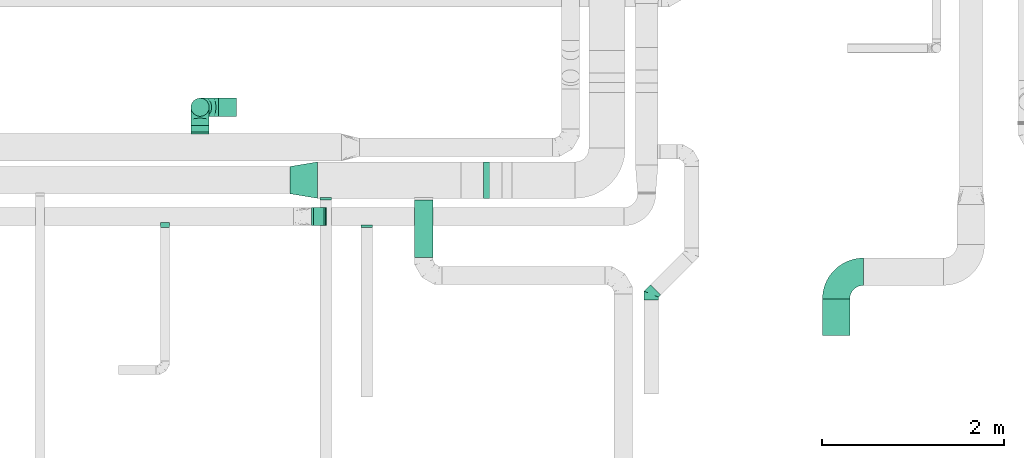
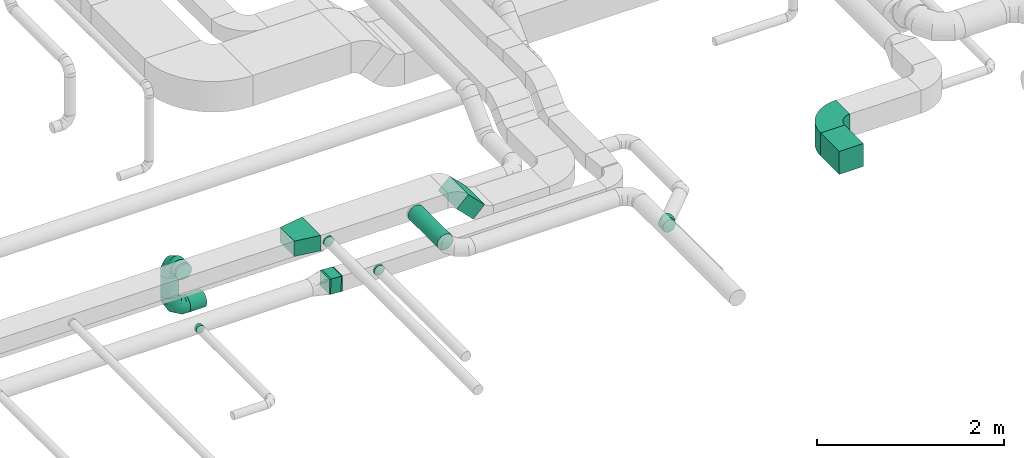
# One storey, part 26 of 60: 11 flow fittings, 7 flow segments.
"""IFC2X3 building model written with IfcOpenShell, lengths in millimetres."""

from ifc_helpers import new_model, entity, si_unit, converted_unit, derived_unit, direction, frame, frame_2d, origin, origin_2d_with_axis, place, context, subcontext, project, spatial, polyline, circle_curve, parameter, trimmed, segment, composite_curve, rectangle, circle, outline, extrude, faceted_brep, source, transform, mapped, material, type_object, type_shapes, element, save


model = new_model("IFC2X3")

# Units and contexts
model_context = context("Model", 3, precision=0.01, world=origin(), true_north=direction((6.12303176911189e-17, 1.0)))
body_context = subcontext(model_context, "Body", "Model", "MODEL_VIEW")
ifc_project = project(units=[si_unit("LENGTHUNIT", "METRE", prefix="MILLI"), si_unit("AREAUNIT", "SQUARE_METRE"), si_unit("VOLUMEUNIT", "CUBIC_METRE"), converted_unit("PLANEANGLEUNIT", "DEGREE", entity("IfcRatioMeasure", 0.0174532925199433), si_unit("PLANEANGLEUNIT", "RADIAN"), dimensions=[0, 0, 0, 0, 0, 0, 0]), si_unit("MASSUNIT", "GRAM", prefix="KILO"), derived_unit("MASSDENSITYUNIT", [(si_unit("MASSUNIT", "GRAM", prefix="KILO"), 1), (si_unit("LENGTHUNIT", "METRE"), -3)]), derived_unit("MOMENTOFINERTIAUNIT", [(si_unit("LENGTHUNIT", "METRE"), 4)]), si_unit("TIMEUNIT", "SECOND"), si_unit("FREQUENCYUNIT", "HERTZ"), si_unit("THERMODYNAMICTEMPERATUREUNIT", "DEGREE_CELSIUS"), derived_unit("THERMALTRANSMITTANCEUNIT", [(si_unit("MASSUNIT", "GRAM", prefix="KILO"), 1), (si_unit("THERMODYNAMICTEMPERATUREUNIT", "KELVIN"), -1), (si_unit("TIMEUNIT", "SECOND"), -3)]), derived_unit("VOLUMETRICFLOWRATEUNIT", [(si_unit("LENGTHUNIT", "METRE"), 3), (si_unit("TIMEUNIT", "SECOND"), -1)]), derived_unit("MASSFLOWRATEUNIT", [(si_unit("MASSUNIT", "GRAM", prefix="KILO"), 1), (si_unit("TIMEUNIT", "SECOND"), -1)]), derived_unit("ROTATIONALFREQUENCYUNIT", [(si_unit("TIMEUNIT", "SECOND"), -1)]), si_unit("ELECTRICCURRENTUNIT", "AMPERE"), si_unit("ELECTRICVOLTAGEUNIT", "VOLT"), si_unit("POWERUNIT", "WATT"), si_unit("FORCEUNIT", "NEWTON", prefix="KILO"), si_unit("ILLUMINANCEUNIT", "LUX"), si_unit("LUMINOUSFLUXUNIT", "LUMEN"), si_unit("LUMINOUSINTENSITYUNIT", "CANDELA"), derived_unit("USERDEFINED", [(si_unit("MASSUNIT", "GRAM", prefix="KILO"), -1), (si_unit("LENGTHUNIT", "METRE"), -2), (si_unit("TIMEUNIT", "SECOND"), 3), (si_unit("LUMINOUSFLUXUNIT", "LUMEN"), 1)]), derived_unit("LINEARVELOCITYUNIT", [(si_unit("LENGTHUNIT", "METRE"), 1), (si_unit("TIMEUNIT", "SECOND"), -1)]), si_unit("PRESSUREUNIT", "PASCAL"), derived_unit("USERDEFINED", [(si_unit("LENGTHUNIT", "METRE"), -2), (si_unit("MASSUNIT", "GRAM", prefix="KILO"), 1), (si_unit("TIMEUNIT", "SECOND"), -2)]), derived_unit("LINEARFORCEUNIT", [(si_unit("MASSUNIT", "GRAM", prefix="KILO"), 1), (si_unit("LENGTHUNIT", "METRE"), 1), (si_unit("TIMEUNIT", "SECOND"), -2), (si_unit("LENGTHUNIT", "METRE"), -1)]), derived_unit("PLANARFORCEUNIT", [(si_unit("MASSUNIT", "GRAM", prefix="KILO"), 1), (si_unit("LENGTHUNIT", "METRE"), 1), (si_unit("TIMEUNIT", "SECOND"), -2), (si_unit("LENGTHUNIT", "METRE"), -2)])], contexts=[model_context])

# Site, building, storey
site_placement = place(None, origin())
site = spatial("IfcSite", under=ifc_project, at=site_placement, CompositionType="ELEMENT")
building_placement = place(site_placement, origin())
building = spatial("IfcBuilding", under=site, at=building_placement, CompositionType="ELEMENT")
storey_placement = place(building_placement, frame((0.0, 0.0, 19800.0)))
storey = spatial("IfcBuildingStorey", under=building, at=storey_placement, CompositionType="ELEMENT", Elevation=19800.0)

# Flow segments
duct_segment_type_1 = type_object("IfcDuctSegmentType", PredefinedType="NOTDEFINED")
flow_segment_1_placement = place(storey_placement, frame((45074.61, 5025.34, 3252.51)))
element("IfcFlowSegment", 1, at=flow_segment_1_placement, inside=storey, type_object=duct_segment_type_1, context=body_context, shape_type="SweptSolid", body=[
    extrude(rectangle(XDim=287.867965644102, YDim=199.999999999998, at=origin_2d_with_axis()), frame((172.49, 0.0, 172.49), z_axis=(0.0, 1.0, 0.0), x_axis=(0.707106781186517, 0.0, -0.707106781186578)), (0.0, 0.0, 1.0), 400.000000000001),
])
flow_segment_2_placement = place(storey_placement, frame((48935.38, 3519.45, 3470.0)))
element("IfcFlowSegment", 2, at=flow_segment_2_placement, inside=storey, type_object=duct_segment_type_1, context=body_context, shape_type="SweptSolid", body=[
    extrude(rectangle(XDim=400.000000000009, YDim=300.000000000001, at=origin_2d_with_axis()), frame((150.0, 200.0, 0.0), z_axis=(0.0, 0.0, 1.0), x_axis=(0.0, -1.0, 0.0)), (0.0, 0.0, 1.0), 300.000000000001),
])
flow_segment_3_placement = place(storey_placement, frame((43335.44, 4724.52, 3120.7)))
element("IfcFlowSegment", 3, at=flow_segment_3_placement, inside=storey, type_object=duct_segment_type_1, context=body_context, shape_type="SweptSolid", body=[
    extrude(rectangle(XDim=129.930530110866, YDim=200.0, at=origin_2d_with_axis()), frame((64.81, 100.0, 4.42), z_axis=(0.0680418664621352, 0.0, 0.997682466723932), x_axis=(0.997682466723932, 0.0, -0.0680418664621352)), (0.0, 0.0, 1.0), 200.000000000001),
])
duct_segment_type_2 = type_object("IfcDuctSegmentType", PredefinedType="NOTDEFINED")
flow_segment_4_placement = place(storey_placement, frame((42000.81, 5755.05, 3148.4)))
element("IfcFlowSegment", 4, at=flow_segment_4_placement, inside=storey, type_object=duct_segment_type_2, context=body_context, shape_type="SweptSolid", body=[
    extrude(circle(Radius=100.0, at=origin_2d_with_axis()), frame((101.6, 0.0, 101.6), z_axis=(0.0, 1.0, 0.0), x_axis=(1.0, 0.0, 0.0)), (0.0, 0.0, 1.0), 69.9999999999678),
])
flow_segment_5_placement = place(storey_placement, frame((42000.81, 5923.46, 2787.5)))
element("IfcFlowSegment", 5, at=flow_segment_5_placement, inside=storey, type_object=duct_segment_type_2, context=body_context, shape_type="SweptSolid", body=[
    extrude(circle(Radius=100.0, at=origin_2d_with_axis()), frame((101.6, 101.6, 0.0), z_axis=(0.0, 0.0, 1.0), x_axis=(-1.0, 0.0, 0.0)), (0.0, 0.0, 1.0), 262.500000000001),
])
flow_segment_6_placement = place(storey_placement, frame((42302.4, 5923.46, 2485.9)))
element("IfcFlowSegment", 6, at=flow_segment_6_placement, inside=storey, type_object=duct_segment_type_2, context=body_context, shape_type="SweptSolid", body=[
    extrude(circle(Radius=100.0, at=origin_2d_with_axis()), frame((0.0, 101.6, 101.6), z_axis=(1.0, 0.0, 0.0), x_axis=(0.0, -1.0, 0.0)), (0.0, 0.0, 1.0), 200.000000000015),
])
flow_segment_7_placement = place(storey_placement, frame((44456.24, 4376.59, 3498.4)))
element("IfcFlowSegment", 7, at=flow_segment_7_placement, inside=storey, type_object=duct_segment_type_2, context=body_context, shape_type="SweptSolid", body=[
    extrude(circle(Radius=100.0, at=origin_2d_with_axis()), frame((101.6, 0.0, 101.6), z_axis=(0.0, 1.0, 0.0), x_axis=(-1.0, 0.0, 0.0)), (0.0, 0.0, 1.0), 628.750000000001),
])

# Flow fittings
ifc_material = material()
duct_fitting_type_1 = type_object("IfcDuctFittingType", PredefinedType="NOTDEFINED", material=ifc_material)
shared_shape_1 = source(origin(), body_context, "Body", "SweptSolid", [
    extrude(outline(polyline([(-180.84, -172.62), (123.3, -172.62), (172.62, 123.3), (-115.08, 221.94), (-180.84, -172.62)])), frame((150.0, 0.0, -100.0), z_axis=(0.0, 0.0, 1.0), x_axis=(0.986393923832144, 0.164398987305356, 0.0)), (0.0, 0.0, 1.0), 200.0),
])
type_shapes(duct_fitting_type_1, [shared_shape_1])
flow_fitting_1_placement = place(storey_placement, frame((43391.97, 5225.34, 3600.0), z_axis=(0.0, 0.0, 1.0), x_axis=(-1.0, 0.0, 0.0)))
element("IfcFlowFitting", 8, at=flow_fitting_1_placement, inside=storey, type_object=duct_fitting_type_1, material=ifc_material, context=body_context, shape_type="MappedRepresentation", body=[
    mapped(shared_shape_1, transform((0.0, 0.0, 0.0), scale=1.0)),
])
duct_fitting_type_2 = type_object("IfcDuctFittingType", PredefinedType="NOTDEFINED", material=ifc_material)
shared_shape_2 = source(origin(), body_context, "Body", "Brep", [
    faceted_brep([(-200.0, 0.0, -100.0), (-200.0, -25.88, -96.59), (-200.0, -50.0, -86.6), (-200.0, -70.71, -70.71), (-200.0, -86.6, -50.0), (-200.0, -96.59, -25.88), (-200.0, -100.0, 0.0), (-200.0, -96.59, 25.88), (-200.0, -86.6, 50.0), (-200.0, -70.71, 70.71), (-200.0, -50.0, 86.6), (-200.0, -25.88, 96.59), (-200.0, 0.0, 100.0), (-200.0, 25.88, 96.59), (-200.0, 50.0, 86.6), (-200.0, 70.71, 70.71), (-200.0, 86.6, 50.0), (-200.0, 96.59, 25.88), (-200.0, 100.0, 0.0), (-200.0, 96.59, -25.88), (-200.0, 86.6, -50.0), (-200.0, 70.71, -70.71), (-200.0, 50.0, -86.6), (-200.0, 25.88, -96.59), (-153.35, 25.88, 96.59), (-159.81, 50.0, 86.6), (-146.41, 0.0, 100.0), (-165.36, 70.71, 70.71), (-172.29, 96.59, 25.88), (-173.21, 100.0, 0.0), (-169.62, 86.6, 50.0), (-169.62, 86.6, -50.0), (-165.36, 70.71, -70.71), (-172.29, 96.59, -25.88), (-153.35, 25.88, -96.59), (-146.41, 0.0, -100.0), (-159.81, 50.0, -86.6), (-139.48, -25.88, -96.59), (-133.01, -50.0, -86.6), (-127.46, -70.71, -70.71), (-123.21, -86.6, -50.0), (-120.53, -96.59, -25.88), (-119.62, -100.0, 0.0), (-120.53, -96.59, 25.88), (-123.21, -86.6, 50.0), (-127.46, -70.71, 70.71), (-133.01, -50.0, 86.6), (-139.48, -25.88, 96.59), (-72.54, 72.54, 96.59), (-90.19, 90.19, 86.6), (-53.59, 53.59, 100.0), (-105.35, 105.35, 70.71), (-116.99, 116.99, 50.0), (-124.3, 124.3, 25.88), (-126.79, 126.79, 0.0), (-124.3, 124.3, -25.88), (-116.99, 116.99, -50.0), (-105.35, 105.35, -70.71), (-72.54, 72.54, -96.59), (-53.59, 53.59, -100.0), (-90.19, 90.19, -86.6), (-34.64, 34.64, -96.59), (-16.99, 16.99, -86.6), (-1.83, 1.83, -70.71), (9.81, -9.81, -50.0), (17.12, -17.12, -25.88), (19.62, -19.62, 0.0), (17.12, -17.12, 25.88), (9.81, -9.81, 50.0), (-1.83, 1.83, 70.71), (-16.99, 16.99, 86.6), (-34.64, 34.64, 96.59), (-25.88, 153.35, 96.59), (-50.0, 159.81, 86.6), (0.0, 146.41, 100.0), (-70.71, 165.36, 70.71), (-86.6, 169.62, 50.0), (-96.59, 172.29, 25.88), (-100.0, 173.21, 0.0), (-96.59, 172.29, -25.88), (-86.6, 169.62, -50.0), (-70.71, 165.36, -70.71), (-25.88, 153.35, -96.59), (0.0, 146.41, -100.0), (-50.0, 159.81, -86.6), (25.88, 139.48, -96.59), (50.0, 133.01, -86.6), (70.71, 127.46, -70.71), (86.6, 123.21, -50.0), (96.59, 120.53, -25.88), (100.0, 119.62, 0.0), (96.59, 120.53, 25.88), (86.6, 123.21, 50.0), (70.71, 127.46, 70.71), (50.0, 133.01, 86.6), (25.88, 139.48, 96.59), (-25.88, 200.0, -96.59), (-50.0, 200.0, -86.6), (-70.71, 200.0, -70.71), (-86.6, 200.0, -50.0), (-96.59, 200.0, -25.88), (-100.0, 200.0, 0.0), (-96.59, 200.0, 25.88), (-86.6, 200.0, 50.0), (-70.71, 200.0, 70.71), (-50.0, 200.0, 86.6), (-25.88, 200.0, 96.59), (0.0, 200.0, 100.0), (25.88, 200.0, 96.59), (50.0, 200.0, 86.6), (70.71, 200.0, 70.71), (86.6, 200.0, 50.0), (96.59, 200.0, 25.88), (100.0, 200.0, 0.0), (96.59, 200.0, -25.88), (86.6, 200.0, -50.0), (70.71, 200.0, -70.71), (50.0, 200.0, -86.6), (25.88, 200.0, -96.59), (0.0, 200.0, -100.0)], [[[0, 1, 2, 3, 4, 5, 6, 7, 8, 9, 10, 11, 12, 13, 14, 15, 16, 17, 18, 19, 20, 21, 22, 23]], [[24, 25, 14, 13]], [[26, 24, 13, 12]], [[14, 25, 27, 15]], [[28, 29, 18, 17]], [[30, 28, 17, 16]], [[15, 27, 30, 16]], [[20, 31, 32, 21]], [[33, 31, 20, 19]], [[18, 29, 33, 19]], [[34, 35, 0, 23]], [[36, 34, 23, 22]], [[32, 36, 22, 21]], [[1, 0, 35, 37]], [[2, 1, 37, 38]], [[38, 39, 3, 2]], [[5, 4, 40, 41]], [[6, 5, 41, 42]], [[39, 40, 4, 3]], [[6, 42, 43, 7]], [[7, 43, 44, 8]], [[8, 44, 45, 9]], [[9, 45, 46, 10]], [[10, 46, 47, 11]], [[26, 12, 11, 47]], [[48, 49, 25, 24]], [[50, 48, 24, 26]], [[27, 25, 49, 51]], [[52, 53, 28, 30]], [[51, 52, 30, 27]], [[29, 28, 53, 54]], [[55, 56, 31, 33]], [[54, 55, 33, 29]], [[32, 31, 56, 57]], [[58, 59, 35, 34]], [[60, 58, 34, 36]], [[57, 60, 36, 32]], [[37, 35, 59, 61]], [[38, 37, 61, 62]], [[39, 38, 62, 63]], [[41, 40, 64, 65]], [[42, 41, 65, 66]], [[63, 64, 40, 39]], [[43, 42, 66, 67]], [[44, 43, 67, 68]], [[68, 69, 45, 44]], [[46, 45, 69, 70]], [[47, 46, 70, 71]], [[26, 47, 71, 50]], [[72, 73, 49, 48]], [[74, 72, 48, 50]], [[51, 49, 73, 75]], [[76, 77, 53, 52]], [[75, 76, 52, 51]], [[54, 53, 77, 78]], [[79, 80, 56, 55]], [[78, 79, 55, 54]], [[57, 56, 80, 81]], [[82, 83, 59, 58]], [[84, 82, 58, 60]], [[81, 84, 60, 57]], [[61, 59, 83, 85]], [[62, 61, 85, 86]], [[63, 62, 86, 87]], [[65, 64, 88, 89]], [[66, 65, 89, 90]], [[87, 88, 64, 63]], [[67, 66, 90, 91]], [[68, 67, 91, 92]], [[92, 93, 69, 68]], [[70, 69, 93, 94]], [[71, 70, 94, 95]], [[50, 71, 95, 74]], [[96, 97, 98, 99, 100, 101, 102, 103, 104, 105, 106, 107, 108, 109, 110, 111, 112, 113, 114, 115, 116, 117, 118, 119]], [[72, 74, 107, 106]], [[73, 72, 106, 105]], [[75, 73, 105, 104]], [[102, 101, 78, 77]], [[103, 102, 77, 76]], [[75, 104, 103, 76]], [[78, 101, 100, 79]], [[79, 100, 99, 80]], [[80, 99, 98, 81]], [[84, 97, 96, 82]], [[82, 96, 119, 83]], [[84, 81, 98, 97]], [[118, 117, 86, 85]], [[119, 118, 85, 83]], [[116, 87, 86, 117]], [[88, 115, 114, 89]], [[89, 114, 113, 90]], [[115, 88, 87, 116]], [[91, 90, 113, 112]], [[92, 91, 112, 111]], [[111, 110, 93, 92]], [[95, 94, 109, 108]], [[74, 95, 108, 107]], [[110, 109, 94, 93]]]),
])
type_shapes(duct_fitting_type_2, [shared_shape_2])
for number, where, z_axis, x_axis in (
    (9, (42102.4, 6025.05, 3250.0), (-1.0, 0.0, 0.0), (0.0, 1.0, 0.0)),
    (10, (42102.4, 6025.05, 2587.5), (0.0, -1.0, 0.0), (0.0, 0.0, -1.0)),
):
    element("IfcFlowFitting", number, at=place(storey_placement, frame(where, z_axis=z_axis, x_axis=x_axis)), inside=storey, type_object=duct_fitting_type_2, material=ifc_material, context=body_context, shape_type="MappedRepresentation", body=[
        mapped(shared_shape_2, transform((0.0, 0.0, 0.0), scale=1.0)),
    ])
duct_fitting_type_3 = type_object("IfcDuctFittingType", PredefinedType="NOTDEFINED", material=ifc_material)
shared_shape_3 = source(origin(), body_context, "Body", "Brep", [
    faceted_brep([(20.0, 0.0, -62.5), (20.0, 16.18, -60.37), (20.0, 31.25, -54.13), (20.0, 44.19, -44.19), (20.0, 54.13, -31.25), (20.0, 60.37, -16.18), (20.0, 62.5, 0.0), (20.0, 60.37, 16.18), (20.0, 54.13, 31.25), (20.0, 44.19, 44.19), (20.0, 31.25, 54.13), (20.0, 16.18, 60.37), (20.0, 0.0, 62.5), (20.0, -16.18, 60.37), (20.0, -31.25, 54.13), (20.0, -44.19, 44.19), (20.0, -54.13, 31.25), (20.0, -60.37, 16.18), (20.0, -62.5, 0.0), (20.0, -60.37, -16.18), (20.0, -54.13, -31.25), (20.0, -44.19, -44.19), (20.0, -31.25, -54.13), (20.0, -16.18, -60.37), (0.0, 0.0, 62.5), (-6.1, 0.0, 62.5), (-6.1, -16.18, 60.37), (0.0, -16.18, 60.37), (-6.1, -31.25, 54.13), (0.0, -31.25, 54.13), (0.0, -44.19, 44.19), (-6.1, -44.19, 44.19), (0.0, -54.13, 31.25), (-6.1, -54.13, 31.25), (-6.1, -60.37, 16.18), (0.0, -60.37, 16.18), (-6.1, -62.5, 0.0), (0.0, -62.5, 0.0), (-6.1, -60.37, -16.18), (0.0, -60.37, -16.18), (-6.1, -54.13, -31.25), (0.0, -54.13, -31.25), (0.0, -44.19, -44.19), (-6.1, -44.19, -44.19), (0.0, -31.25, -54.13), (-6.1, -31.25, -54.13), (-6.1, -16.18, -60.37), (0.0, -16.18, -60.37), (-6.1, 0.0, -62.5), (0.0, 0.0, -62.5), (-6.1, 16.18, -60.37), (0.0, 16.18, -60.37), (-6.1, 31.25, -54.13), (0.0, 31.25, -54.13), (0.0, 44.19, -44.19), (-6.1, 44.19, -44.19), (0.0, 54.13, -31.25), (-6.1, 54.13, -31.25), (-6.1, 60.37, -16.18), (0.0, 60.37, -16.18), (-6.1, 62.5, 0.0), (0.0, 62.5, 0.0), (-6.1, 60.37, 16.18), (0.0, 60.37, 16.18), (-6.1, 54.13, 31.25), (0.0, 54.13, 31.25), (0.0, 44.19, 44.19), (-6.1, 44.19, 44.19), (0.0, 31.25, 54.13), (-6.1, 31.25, 54.13), (-6.1, 16.18, 60.37), (0.0, 16.18, 60.37)], [[[0, 1, 2, 3, 4, 5, 6, 7, 8, 9, 10, 11, 12, 13, 14, 15, 16, 17, 18, 19, 20, 21, 22, 23]], [[13, 12, 24, 25, 26, 27]], [[14, 13, 27, 26, 28, 29]], [[30, 15, 14, 29, 28, 31]], [[17, 16, 32, 33, 34, 35]], [[18, 17, 35, 34, 36, 37]], [[32, 16, 15, 30, 31, 33]], [[19, 18, 37, 36, 38, 39]], [[20, 19, 39, 38, 40, 41]], [[42, 21, 20, 41, 40, 43]], [[23, 22, 44, 45, 46, 47]], [[0, 23, 47, 46, 48, 49]], [[44, 22, 21, 42, 43, 45]], [[1, 0, 49, 48, 50, 51]], [[2, 1, 51, 50, 52, 53]], [[54, 3, 2, 53, 52, 55]], [[5, 4, 56, 57, 58, 59]], [[6, 5, 59, 58, 60, 61]], [[56, 4, 3, 54, 55, 57]], [[7, 6, 61, 60, 62, 63]], [[8, 7, 63, 62, 64, 65]], [[66, 9, 8, 65, 64, 67]], [[11, 10, 68, 69, 70, 71]], [[12, 11, 71, 70, 25, 24]], [[68, 10, 9, 66, 67, 69]], [[46, 45, 43, 40, 38, 36, 34, 33, 31, 28, 26, 25, 70, 69, 67, 64, 62, 60, 58, 57, 55, 52, 50, 48]]]),
])
type_shapes(duct_fitting_type_3, [shared_shape_3])
for number, where, z_axis, x_axis in (
    (11, (43480.63, 5025.34, 3600.0), (0.0, 0.0, -1.0), (0.0, -1.0, 0.0)),
    (12, (43931.49, 4724.52, 3250.0), (0.0, 0.0, -1.0), (0.0, -1.0, 0.0)),
):
    element("IfcFlowFitting", number, at=place(storey_placement, frame(where, z_axis=z_axis, x_axis=x_axis)), inside=storey, type_object=duct_fitting_type_3, material=ifc_material, context=body_context, shape_type="MappedRepresentation", body=[
        mapped(shared_shape_3, transform((0.0, 0.0, 0.0), scale=1.0)),
    ])
duct_fitting_type_4 = type_object("IfcDuctFittingType", PredefinedType="NOTDEFINED", material=ifc_material)
shared_shape_4 = source(origin(), body_context, "Body", "Brep", [
    faceted_brep([(-66.27, 0.0, -80.0), (-66.27, -20.71, -77.27), (-66.27, -40.0, -69.28), (-66.27, -56.57, -56.57), (-66.27, -69.28, -40.0), (-66.27, -77.27, -20.71), (-66.27, -80.0, 0.0), (-66.27, -77.27, 20.71), (-66.27, -69.28, 40.0), (-66.27, -56.57, 56.57), (-66.27, -40.0, 69.28), (-66.27, -20.71, 77.27), (-66.27, 0.0, 80.0), (-66.27, 20.71, 77.27), (-66.27, 40.0, 69.28), (-66.27, 56.57, 56.57), (-66.27, 69.28, 40.0), (-66.27, 77.27, 20.71), (-66.27, 80.0, 0.0), (-66.27, 77.27, -20.71), (-66.27, 69.28, -40.0), (-66.27, 56.57, -56.57), (-66.27, 40.0, -69.28), (-66.27, 20.71, -77.27), (-8.58, 20.71, 77.27), (-16.57, 40.0, 69.28), (0.0, 0.0, 80.0), (-23.43, 56.57, 56.57), (-28.7, 69.28, 40.0), (-32.01, 77.27, 20.71), (-33.14, 80.0, 0.0), (-32.01, 77.27, -20.71), (-28.7, 69.28, -40.0), (-23.43, 56.57, -56.57), (-8.58, 20.71, -77.27), (0.0, 0.0, -80.0), (-16.57, 40.0, -69.28), (8.58, -20.71, -77.27), (16.57, -40.0, -69.28), (23.43, -56.57, -56.57), (28.7, -69.28, -40.0), (32.01, -77.27, -20.71), (33.14, -80.0, 0.0), (32.01, -77.27, 20.71), (28.7, -69.28, 40.0), (23.43, -56.57, 56.57), (16.57, -40.0, 69.28), (8.58, -20.71, 77.27), (46.86, 46.86, 80.0), (32.22, 61.5, 77.27), (18.58, 75.15, 69.28), (6.86, 86.86, 56.57), (-2.13, 95.85, 40.0), (-7.78, 101.5, 20.71), (-9.71, 103.43, 0.0), (-7.78, 101.5, -20.71), (-2.13, 95.85, -40.0), (6.86, 86.86, -56.57), (18.58, 75.15, -69.28), (32.22, 61.5, -77.27), (46.86, 46.86, -80.0), (61.5, 32.22, -77.27), (75.15, 18.58, -69.28), (86.86, 6.86, -56.57), (95.85, -2.13, -40.0), (101.5, -7.78, -20.71), (103.43, -9.71, 0.0), (101.5, -7.78, 20.71), (95.85, -2.13, 40.0), (86.86, 6.86, 56.57), (75.15, 18.58, 69.28), (61.5, 32.22, 77.27)], [[[0, 1, 2, 3, 4, 5, 6, 7, 8, 9, 10, 11, 12, 13, 14, 15, 16, 17, 18, 19, 20, 21, 22, 23]], [[24, 25, 14, 13]], [[26, 24, 13, 12]], [[14, 25, 27, 15]], [[28, 29, 17, 16]], [[28, 16, 15, 27]], [[30, 18, 17, 29]], [[31, 32, 20, 19]], [[30, 31, 19, 18]], [[32, 33, 21, 20]], [[34, 35, 0, 23]], [[36, 34, 23, 22]], [[33, 36, 22, 21]], [[1, 0, 35, 37]], [[2, 1, 37, 38]], [[38, 39, 3, 2]], [[5, 4, 40, 41]], [[6, 5, 41, 42]], [[39, 40, 4, 3]], [[6, 42, 43, 7]], [[7, 43, 44, 8]], [[8, 44, 45, 9]], [[9, 45, 46, 10]], [[10, 46, 47, 11]], [[26, 12, 11, 47]], [[24, 26, 48, 49]], [[25, 24, 49, 50]], [[27, 25, 50, 51]], [[29, 28, 52, 53]], [[30, 29, 53, 54]], [[51, 52, 28, 27]], [[30, 54, 55, 31]], [[31, 55, 56, 32]], [[57, 33, 32, 56]], [[36, 58, 59, 34]], [[34, 59, 60, 35]], [[58, 36, 33, 57]], [[35, 60, 61, 37]], [[37, 61, 62, 38]], [[63, 39, 38, 62]], [[40, 64, 65, 41]], [[41, 65, 66, 42]], [[64, 40, 39, 63]], [[43, 42, 66, 67]], [[44, 43, 67, 68]], [[68, 69, 45, 44]], [[47, 46, 70, 71]], [[26, 47, 71, 48]], [[69, 70, 46, 45]], [[59, 58, 57, 56, 55, 54, 53, 52, 51, 50, 49, 48, 71, 70, 69, 68, 67, 66, 65, 64, 63, 62, 61, 60]]]),
])
type_shapes(duct_fitting_type_4, [shared_shape_4])
flow_fitting_2_placement = place(storey_placement, frame((47056.97, 3972.54, 3219.89), z_axis=(0.0, 0.0, 1.0), x_axis=(-0.707106781186556, -0.707106781186539, 0.0)))
element("IfcFlowFitting", 13, at=flow_fitting_2_placement, inside=storey, type_object=duct_fitting_type_4, material=ifc_material, context=body_context, shape_type="MappedRepresentation", body=[
    mapped(shared_shape_4, transform((0.0, 0.0, 0.0), scale=1.0)),
])
duct_fitting_type_5 = type_object("IfcDuctFittingType", PredefinedType="NOTDEFINED", material=ifc_material)
shared_shape_5 = source(origin(), body_context, "Body", "Brep", [
    faceted_brep([(20.0, 25.88, -96.59), (20.0, 50.0, -86.6), (20.0, 70.71, -70.71), (20.0, 86.6, -50.0), (20.0, 96.59, -25.88), (20.0, 100.0, 0.0), (20.0, 96.59, 25.88), (20.0, 86.6, 50.0), (20.0, 70.71, 70.71), (20.0, 50.0, 86.6), (20.0, 25.88, 96.59), (20.0, 0.0, 100.0), (20.0, -25.88, 96.59), (20.0, -50.0, 86.6), (20.0, -70.71, 70.71), (20.0, -86.6, 50.0), (20.0, -96.59, 25.88), (20.0, -100.0, 0.0), (20.0, -96.59, -25.88), (20.0, -86.6, -50.0), (20.0, -70.71, -70.71), (20.0, -50.0, -86.6), (20.0, -25.88, -96.59), (20.0, 0.0, -100.0), (0.0, 0.0, 100.0), (0.0, 25.88, 96.59), (-6.1, 25.88, 96.59), (-6.1, 0.0, 100.0), (0.0, 50.0, 86.6), (-6.1, 50.0, 86.6), (0.0, 70.71, 70.71), (-6.1, 70.71, 70.71), (0.0, 86.6, 50.0), (0.0, 96.59, 25.88), (-6.1, 96.59, 25.88), (-6.1, 86.6, 50.0), (0.0, 100.0, 0.0), (-6.1, 100.0, 0.0), (0.0, 96.59, -25.88), (-6.1, 96.59, -25.88), (0.0, 86.6, -50.0), (-6.1, 86.6, -50.0), (0.0, 70.71, -70.71), (-6.1, 70.71, -70.71), (0.0, 50.0, -86.6), (0.0, 25.88, -96.59), (-6.1, 25.88, -96.59), (-6.1, 50.0, -86.6), (0.0, 0.0, -100.0), (-6.1, 0.0, -100.0), (0.0, -25.88, -96.59), (-6.1, -25.88, -96.59), (0.0, -50.0, -86.6), (-6.1, -50.0, -86.6), (0.0, -70.71, -70.71), (-6.1, -70.71, -70.71), (0.0, -86.6, -50.0), (0.0, -96.59, -25.88), (-6.1, -96.59, -25.88), (-6.1, -86.6, -50.0), (0.0, -100.0, 0.0), (-6.1, -100.0, 0.0), (0.0, -96.59, 25.88), (-6.1, -96.59, 25.88), (0.0, -86.6, 50.0), (-6.1, -86.6, 50.0), (0.0, -70.71, 70.71), (-6.1, -70.71, 70.71), (0.0, -50.0, 86.6), (0.0, -25.88, 96.59), (-6.1, -25.88, 96.59), (-6.1, -50.0, 86.6)], [[[0, 1, 2, 3, 4, 5, 6, 7, 8, 9, 10, 11, 12, 13, 14, 15, 16, 17, 18, 19, 20, 21, 22, 23]], [[24, 11, 10, 25, 26, 27]], [[25, 10, 9, 28, 29, 26]], [[28, 9, 8, 30, 31, 29]], [[32, 7, 6, 33, 34, 35]], [[33, 6, 5, 36, 37, 34]], [[30, 8, 7, 32, 35, 31]], [[36, 5, 4, 38, 39, 37]], [[38, 4, 3, 40, 41, 39]], [[40, 3, 2, 42, 43, 41]], [[44, 1, 0, 45, 46, 47]], [[45, 0, 23, 48, 49, 46]], [[42, 2, 1, 44, 47, 43]], [[48, 23, 22, 50, 51, 49]], [[50, 22, 21, 52, 53, 51]], [[52, 21, 20, 54, 55, 53]], [[56, 19, 18, 57, 58, 59]], [[57, 18, 17, 60, 61, 58]], [[54, 20, 19, 56, 59, 55]], [[60, 17, 16, 62, 63, 61]], [[62, 16, 15, 64, 65, 63]], [[64, 15, 14, 66, 67, 65]], [[68, 13, 12, 69, 70, 71]], [[69, 12, 11, 24, 27, 70]], [[66, 14, 13, 68, 71, 67]], [[49, 51, 53, 55, 59, 58, 61, 63, 65, 67, 71, 70, 27, 26, 29, 31, 35, 34, 37, 39, 41, 43, 47, 46]]]),
])
type_shapes(duct_fitting_type_5, [shared_shape_5])
flow_fitting_3_placement = place(storey_placement, frame((42102.4, 5735.05, 3250.0), z_axis=(0.0, 0.0, -1.0), x_axis=(0.0, 1.0, 0.0)))
element("IfcFlowFitting", 14, at=flow_fitting_3_placement, inside=storey, type_object=duct_fitting_type_5, material=ifc_material, context=body_context, shape_type="MappedRepresentation", body=[
    mapped(shared_shape_5, transform((0.0, 0.0, 0.0), scale=1.0)),
])
duct_fitting_type_6 = type_object("IfcDuctFittingType", PredefinedType="NOTDEFINED", material=ifc_material)
shared_shape_6 = source(origin(), body_context, "Body", "Brep", [
    faceted_brep([(20.02, 0.0, -50.0), (20.02, 12.94, -48.3), (20.02, 25.0, -43.3), (20.02, 35.36, -35.36), (20.02, 43.3, -25.0), (20.02, 48.3, -12.94), (20.02, 50.0, 0.0), (20.02, 48.3, 12.94), (20.02, 43.3, 25.0), (20.02, 35.36, 35.36), (20.02, 25.0, 43.3), (20.02, 12.94, 48.3), (20.02, 0.0, 50.0), (20.02, -12.94, 48.3), (20.02, -25.0, 43.3), (20.02, -35.36, 35.36), (20.02, -43.3, 25.0), (20.02, -48.3, 12.94), (20.02, -50.0, 0.0), (20.02, -48.3, -12.94), (20.02, -43.3, -25.0), (20.02, -35.36, -35.36), (20.02, -25.0, -43.3), (20.02, -12.94, -48.3), (0.0, 0.0, 50.0), (-32.77, 0.0, 50.0), (-32.77, -12.94, 48.3), (0.0, -12.94, 48.3), (-32.77, -25.0, 43.3), (0.0, -25.0, 43.3), (0.0, -35.36, 35.36), (-32.77, -35.36, 35.36), (0.0, -43.3, 25.0), (-32.77, -43.3, 25.0), (-32.77, -48.3, 12.94), (0.0, -48.3, 12.94), (-32.77, -50.0, 0.0), (0.0, -50.0, 0.0), (-32.77, -48.3, -12.94), (0.0, -48.3, -12.94), (-32.77, -43.3, -25.0), (0.0, -43.3, -25.0), (0.0, -35.36, -35.36), (-32.77, -35.36, -35.36), (0.0, -25.0, -43.3), (-32.77, -25.0, -43.3), (-32.77, -12.94, -48.3), (0.0, -12.94, -48.3), (-32.77, 0.0, -50.0), (0.0, 0.0, -50.0), (-32.77, 12.94, -48.3), (0.0, 12.94, -48.3), (-32.77, 25.0, -43.3), (0.0, 25.0, -43.3), (0.0, 35.36, -35.36), (-32.77, 35.36, -35.36), (0.0, 43.3, -25.0), (-32.77, 43.3, -25.0), (-32.77, 48.3, -12.94), (0.0, 48.3, -12.94), (-32.77, 50.0, 0.0), (0.0, 50.0, 0.0), (-32.77, 48.3, 12.94), (0.0, 48.3, 12.94), (-32.77, 43.3, 25.0), (0.0, 43.3, 25.0), (0.0, 35.36, 35.36), (-32.77, 35.36, 35.36), (0.0, 25.0, 43.3), (-32.77, 25.0, 43.3), (-32.77, 12.94, 48.3), (0.0, 12.94, 48.3)], [[[0, 1, 2, 3, 4, 5, 6, 7, 8, 9, 10, 11, 12, 13, 14, 15, 16, 17, 18, 19, 20, 21, 22, 23]], [[13, 12, 24, 25, 26, 27]], [[14, 13, 27, 26, 28, 29]], [[30, 15, 14, 29, 28, 31]], [[17, 16, 32, 33, 34, 35]], [[18, 17, 35, 34, 36, 37]], [[32, 16, 15, 30, 31, 33]], [[19, 18, 37, 36, 38, 39]], [[20, 19, 39, 38, 40, 41]], [[42, 21, 20, 41, 40, 43]], [[23, 22, 44, 45, 46, 47]], [[0, 23, 47, 46, 48, 49]], [[44, 22, 21, 42, 43, 45]], [[1, 0, 49, 48, 50, 51]], [[2, 1, 51, 50, 52, 53]], [[54, 3, 2, 53, 52, 55]], [[5, 4, 56, 57, 58, 59]], [[6, 5, 59, 58, 60, 61]], [[56, 4, 3, 54, 55, 57]], [[7, 6, 61, 60, 62, 63]], [[8, 7, 63, 62, 64, 65]], [[66, 9, 8, 65, 64, 67]], [[11, 10, 68, 69, 70, 71]], [[12, 11, 71, 70, 25, 24]], [[68, 10, 9, 66, 67, 69]], [[46, 45, 43, 40, 38, 36, 34, 33, 31, 28, 26, 25, 70, 69, 67, 64, 62, 60, 58, 57, 55, 52, 50, 48]]]),
])
type_shapes(duct_fitting_type_6, [shared_shape_6])
flow_fitting_4_placement = place(storey_placement, frame((41718.48, 4726.55, 3250.0), z_axis=(0.0, 0.0, -1.0), x_axis=(0.0, -1.0, 0.0)))
element("IfcFlowFitting", 15, at=flow_fitting_4_placement, inside=storey, type_object=duct_fitting_type_6, material=ifc_material, context=body_context, shape_type="MappedRepresentation", body=[
    mapped(shared_shape_6, transform((0.0, 0.0, 0.0), scale=1.0)),
])
duct_fitting_type_7 = type_object("IfcDuctFittingType", PredefinedType="NOTDEFINED", material=ifc_material)
shared_shape_7 = source(origin(), body_context, "Body", "SweptSolid", [
    extrude(outline(composite_curve([segment(polyline([(-300.0, -150.0), (0.0, -150.0)]), True, "CONTINUOUS"), segment(trimmed(circle_curve(frame_2d((150.0, -150.0), x_axis=(0.0, 1.0)), 150.0), [parameter(0.0)], [parameter(90.0)], True, "PARAMETER"), False, "CONTINUOUS"), segment(polyline([(150.0, 0.0), (150.0, 300.0)]), True, "CONTINUOUS"), segment(trimmed(circle_curve(frame_2d((150.0, -150.0), x_axis=(0.0, 1.0)), 450.0), [parameter(0.0)], [parameter(90.0000000000001)], True, "PARAMETER"), True, "CONTINUOUS")], self_intersect=False)), frame((-150.0, 150.0, -150.0), z_axis=(0.0, 0.0, 1.0), x_axis=(-1.0, 0.0, 0.0)), (0.0, 0.0, 1.0), 300.0),
])
type_shapes(duct_fitting_type_7, [shared_shape_7])
flow_fitting_5_placement = place(storey_placement, frame((49085.38, 4219.45, 3620.0), z_axis=(0.0, 0.0, 1.0), x_axis=(-1.0, 0.0, 0.0)))
element("IfcFlowFitting", 16, at=flow_fitting_5_placement, inside=storey, type_object=duct_fitting_type_7, material=ifc_material, context=body_context, shape_type="MappedRepresentation", body=[
    mapped(shared_shape_7, transform((0.0, 0.0, 0.0), scale=1.0)),
])
duct_fitting_type_8 = type_object("IfcDuctFittingType", PredefinedType="NOTDEFINED", material=ifc_material)
shared_shape_8 = source(origin(), body_context, "Body", "SweptSolid", [
    extrude(outline(composite_curve([segment(polyline([(-100.29, -8.51), (99.71, -8.51)]), True, "CONTINUOUS"), segment(trimmed(circle_curve(frame_2d((249.71, -8.51), x_axis=(-0.997682466723932, 0.0680418664621315)), 150.0), [parameter(0.0)], [parameter(3.90152621667363)], True, "PARAMETER"), False, "CONTINUOUS"), segment(polyline([(100.06, 1.7), (-99.48, 15.31)]), True, "CONTINUOUS"), segment(trimmed(circle_curve(frame_2d((249.71, -8.51), x_axis=(-0.997682466723932, 0.0680418664621315)), 350.0), [parameter(0.0)], [parameter(3.90152621667363)], True, "PARAMETER"), True, "CONTINUOUS")], self_intersect=False)), frame((-0.01, 0.29, -100.0), z_axis=(0.0, 0.0, 1.0), x_axis=(-0.0680418664621318, 0.997682466723932, 0.0)), (0.0, 0.0, 1.0), 200.0),
])
type_shapes(duct_fitting_type_8, [shared_shape_8])
for number, where, z_axis, x_axis in (
    (17, (43333.75, 4824.52, 3229.89), (0.0, 1.0, 0.0), (1.0, 0.0, 0.0)),
    (18, (43480.37, 4824.52, 3219.89), (0.0, 1.0, 0.0), (-1.0, 0.0, 0.0)),
):
    element("IfcFlowFitting", number, at=place(storey_placement, frame(where, z_axis=z_axis, x_axis=x_axis)), inside=storey, type_object=duct_fitting_type_8, material=ifc_material, context=body_context, shape_type="MappedRepresentation", body=[
        mapped(shared_shape_8, transform((0.0, 0.0, 0.0), scale=1.0)),
    ])

save(model, "model.ifc")
